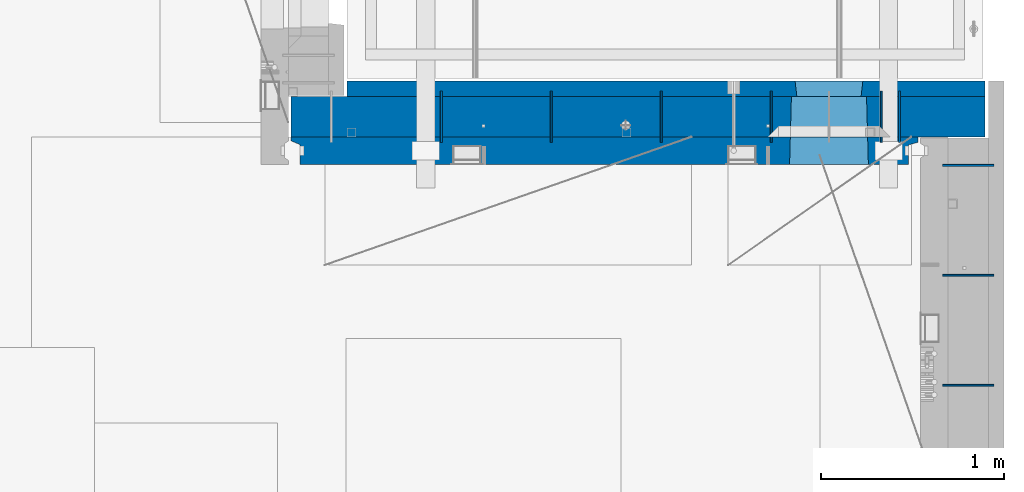
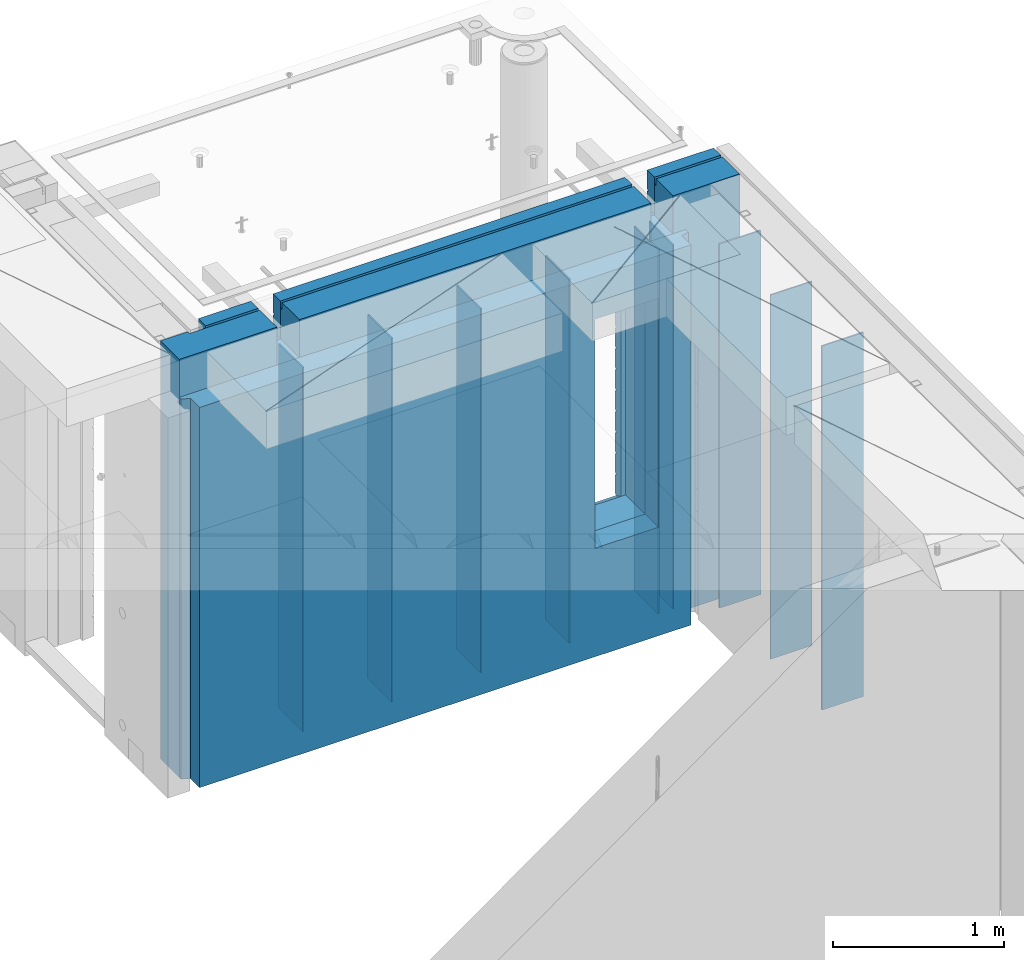
# One storey, part 244 of 352: 12 walls, 2 elements without a shape of their own.
"""IFC2X3 building model written with IfcOpenShell, lengths in millimetres."""

from ifc_helpers import new_model, si_unit, frame, origin_with_axes, place, context, subcontext, project, spatial, faceted_brep, material, type_object, element, aggregate, save


model = new_model("IFC2X3")

# Units and contexts
model_context = context("Model", 3, precision=1e-05, world=origin_with_axes())
body_context = subcontext(model_context, "Body", "Model", "MODEL_VIEW")
ifc_project = project(units=[si_unit("LENGTHUNIT", "METRE", prefix="MILLI"), si_unit("AREAUNIT", "SQUARE_METRE"), si_unit("VOLUMEUNIT", "CUBIC_METRE"), si_unit("MASSUNIT", "GRAM", prefix="KILO"), si_unit("TIMEUNIT", "SECOND"), si_unit("PLANEANGLEUNIT", "RADIAN"), si_unit("SOLIDANGLEUNIT", "STERADIAN"), si_unit("THERMODYNAMICTEMPERATUREUNIT", "DEGREE_CELSIUS"), si_unit("LUMINOUSINTENSITYUNIT", "LUMEN")], contexts=[model_context])

# Site, building, storey
site_placement = place(None, origin_with_axes())
site = spatial("IfcSite", under=ifc_project, at=site_placement, CompositionType="ELEMENT")
building_placement = place(site_placement, origin_with_axes())
building = spatial("IfcBuilding", under=site, at=building_placement, CompositionType="ELEMENT")
storey_placement = place(building_placement, origin_with_axes())
storey = spatial("IfcBuildingStorey", under=building, at=storey_placement, Name="6", CompositionType="ELEMENT", Elevation=0.0)

# Assembly, walls
assembly_1_placement = place(storey_placement, origin_with_axes())
assembly_1 = element("IfcElementAssembly", 1, at=assembly_1_placement, inside=storey, AssemblyPlace="NOTDEFINED", PredefinedType="REINFORCEMENT_UNIT")
ifc_material_1 = material(Name="Undefined")
wall_type_1 = type_object("IfcWallType", PredefinedType="NOTDEFINED")
wall_1_placement = place(assembly_1_placement, frame((32295.0, 20549.9951872276, 98115.0), z_axis=(0.0, 0.0, 1.0), x_axis=(0.0, 1.0, 0.0)))
wall_1 = element("IfcWall", 2, at=wall_1_placement, type_object=wall_type_1, material=ifc_material_1, Name="(PD)", context=body_context, shape_type="Brep", body=[
    faceted_brep([(0.0, 5.0, -1300.0), (0.0, 5.0, 1300.0), (280.0, 5.0, 1300.0), (280.0, 5.0, -1300.0), (0.0, -5.0, 1300.0), (280.0, -5.0, 1300.0), (0.0, -5.0, -1300.0), (280.0, -5.0, -1300.0)], [[[0, 1, 2, 3]], [[1, 4, 5, 2]], [[4, 6, 7, 5]], [[6, 0, 3, 7]], [[5, 7, 3, 2]], [[6, 4, 1, 0]]]),
])
wall_2_placement = place(assembly_1_placement, frame((32895.0, 20549.9951872276, 98115.0), z_axis=(0.0, 0.0, 1.0), x_axis=(0.0, 1.0, 0.0)))
wall_2 = element("IfcWall", 3, at=wall_2_placement, type_object=wall_type_1, material=ifc_material_1, Name="(PD)", context=body_context, shape_type="Brep", body=[
    faceted_brep([(0.0, 5.0, -1300.0), (0.0, 5.0, 1300.0), (280.0, 5.0, 1300.0), (280.0, 5.0, -1300.0), (0.0, -5.0, 1300.0), (280.0, -5.0, 1300.0), (0.0, -5.0, -1300.0), (280.0, -5.0, -1300.0)], [[[0, 1, 2, 3]], [[1, 4, 5, 2]], [[4, 6, 7, 5]], [[6, 0, 3, 7]], [[5, 7, 3, 2]], [[6, 4, 1, 0]]]),
])
wall_3_placement = place(assembly_1_placement, frame((33495.0, 20549.9951872276, 98115.0), z_axis=(0.0, 0.0, 1.0), x_axis=(0.0, 1.0, 0.0)))
wall_3 = element("IfcWall", 4, at=wall_3_placement, type_object=wall_type_1, material=ifc_material_1, Name="(PD)", context=body_context, shape_type="Brep", body=[
    faceted_brep([(0.0, 5.0, -1300.0), (0.0, 5.0, 1300.0), (280.0, 5.0, 1300.0), (280.0, 5.0, -1300.0), (0.0, -5.0, 1300.0), (280.0, -5.0, 1300.0), (0.0, -5.0, -1300.0), (280.0, -5.0, -1300.0)], [[[0, 1, 2, 3]], [[1, 4, 5, 2]], [[4, 6, 7, 5]], [[6, 0, 3, 7]], [[5, 7, 3, 2]], [[6, 4, 1, 0]]]),
])
wall_4_placement = place(assembly_1_placement, frame((34695.0, 20549.9951872276, 98115.0), z_axis=(0.0, 0.0, 1.0), x_axis=(0.0, 1.0, 0.0)))
wall_4 = element("IfcWall", 5, at=wall_4_placement, type_object=wall_type_1, material=ifc_material_1, Name="(PD)", context=body_context, shape_type="Brep", body=[
    faceted_brep([(0.0, 5.0, -1300.0), (0.0, 5.0, 1300.0), (280.0, 5.0, 1300.0), (280.0, 5.0, -1300.0), (0.0, -5.0, 1300.0), (280.0, -5.0, 1300.0), (0.0, -5.0, -1300.0), (280.0, -5.0, -1300.0)], [[[0, 1, 2, 3]], [[1, 4, 5, 2]], [[4, 6, 7, 5]], [[6, 0, 3, 7]], [[5, 7, 3, 2]], [[6, 4, 1, 0]]]),
])
wall_5_placement = place(assembly_1_placement, frame((34795.0, 20549.9951872276, 98115.0), z_axis=(0.0, 0.0, 1.0), x_axis=(0.0, 1.0, 0.0)))
wall_5 = element("IfcWall", 6, at=wall_5_placement, type_object=wall_type_1, material=ifc_material_1, Name="(PD)", context=body_context, shape_type="Brep", body=[
    faceted_brep([(0.0, 5.0, -1300.0), (0.0, 5.0, 1300.0), (280.0, 5.0, 1300.0), (280.0, 5.0, -1300.0), (0.0, -5.0, 1300.0), (280.0, -5.0, 1300.0), (0.0, -5.0, -1300.0), (280.0, -5.0, -1300.0)], [[[0, 1, 2, 3]], [[1, 4, 5, 2]], [[4, 6, 7, 5]], [[6, 0, 3, 7]], [[5, 7, 3, 2]], [[6, 4, 1, 0]]]),
])

assembly_2_placement = place(storey_placement, origin_with_axes())
assembly_2 = element("IfcElementAssembly", 7, at=assembly_2_placement, inside=storey, AssemblyPlace="NOTDEFINED", PredefinedType="REINFORCEMENT_UNIT")
wall_6_placement = place(assembly_2_placement, frame((35030.0, 19225.0002441406, 98115.0), z_axis=(0.0, 0.0, 1.0), x_axis=(1.0, 0.0, 0.0)))
wall_6 = element("IfcWall", 8, at=wall_6_placement, type_object=wall_type_1, material=ifc_material_1, Name="(PD)", context=body_context, shape_type="Brep", body=[
    faceted_brep([(0.0, 5.0, -1300.0), (0.0, 5.0, 1300.0), (280.0, 5.0, 1300.0), (280.0, 5.0, -1300.0), (0.0, -5.0, 1300.0), (280.0, -5.0, 1300.0), (0.0, -5.0, -1300.0), (280.0, -5.0, -1300.0)], [[[0, 1, 2, 3]], [[1, 4, 5, 2]], [[4, 6, 7, 5]], [[6, 0, 3, 7]], [[5, 7, 3, 2]], [[6, 4, 1, 0]]]),
])
wall_7_placement = place(assembly_2_placement, frame((35030.0, 19825.0002441406, 98115.0), z_axis=(0.0, 0.0, 1.0), x_axis=(1.0, 0.0, 0.0)))
wall_7 = element("IfcWall", 9, at=wall_7_placement, type_object=wall_type_1, material=ifc_material_1, Name="(PD)", context=body_context, shape_type="Brep", body=[
    faceted_brep([(0.0, 5.0, -1300.0), (0.0, 5.0, 1300.0), (280.0, 5.0, 1300.0), (280.0, 5.0, -1300.0), (0.0, -5.0, 1300.0), (280.0, -5.0, 1300.0), (0.0, -5.0, -1300.0), (280.0, -5.0, -1300.0)], [[[0, 1, 2, 3]], [[1, 4, 5, 2]], [[4, 6, 7, 5]], [[6, 0, 3, 7]], [[5, 7, 3, 2]], [[6, 4, 1, 0]]]),
])

# Wall
wall_8_placement = place(assembly_1_placement, frame((34095.0, 20549.9951872276, 98115.0), z_axis=(0.0, 0.0, 1.0), x_axis=(0.0, 1.0, 0.0)))
wall_8 = element("IfcWall", 10, at=wall_8_placement, type_object=wall_type_1, material=ifc_material_1, Name="(PD)", context=body_context, shape_type="Brep", body=[
    faceted_brep([(0.0, 5.0, -1300.0), (0.0, 5.0, 1300.0), (280.0, 5.0, 1300.0), (280.0, 5.0, -1300.0), (0.0, -5.0, 1300.0), (280.0, -5.0, 1300.0), (0.0, -5.0, -1300.0), (280.0, -5.0, -1300.0)], [[[0, 1, 2, 3]], [[1, 4, 5, 2]], [[4, 6, 7, 5]], [[6, 0, 3, 7]], [[5, 7, 3, 2]], [[6, 4, 1, 0]]]),
])

wall_9_placement = place(assembly_2_placement, frame((35030.0, 20425.0002441406, 98115.0), z_axis=(0.0, 0.0, 1.0), x_axis=(1.0, 0.0, 0.0)))
wall_9 = element("IfcWall", 11, at=wall_9_placement, type_object=wall_type_1, material=ifc_material_1, Name="(PD)", context=body_context, shape_type="Brep", body=[
    faceted_brep([(0.0, 5.0, -1300.0), (0.0, 5.0, 1300.0), (280.0, 5.0, 1300.0), (280.0, 5.0, -1300.0), (0.0, -5.0, 1300.0), (280.0, -5.0, 1300.0), (0.0, -5.0, -1300.0), (280.0, -5.0, -1300.0)], [[[0, 1, 2, 3]], [[1, 4, 5, 2]], [[4, 6, 7, 5]], [[6, 0, 3, 7]], [[5, 7, 3, 2]], [[6, 4, 1, 0]]]),
])

aggregate(assembly_2, [wall_6, wall_7, wall_9])

ifc_material_2 = material(Name="COS5gt")
wall_type_2 = type_object("IfcWallType", PredefinedType="NOTDEFINED")
wall_10_placement = place(assembly_1_placement, frame((31475.0, 20689.9951872276, 98247.5), z_axis=(0.0, 0.0, 1.0), x_axis=(1.0, 0.0, 0.0)))
wall_10 = element("IfcWall", 12, at=wall_10_placement, type_object=wall_type_2, material=ifc_material_2, context=body_context, shape_type="Brep", body=[
    faceted_brep([(810.0, 110.0, 1442.5), (810.0, 90.0, 1442.5), (3185.0, 90.0, 1442.5), (3185.0, 110.0, 1442.5), (810.0, 90.0, 1492.5), (810.0, -110.0, 1492.5), (3185.0, -110.0, 1492.5), (3185.0, 90.0, 1492.5), (184.0, 90.0, 1442.5), (184.0, 90.0, 1492.5), (660.0, 90.0, 1492.5), (660.0, 90.0, 1442.5), (184.0, 110.0, 1492.5), (184.0, 110.0, 1442.5), (0.0, 110.0, 1492.5), (0.0, -110.0, 1492.5), (660.0, -110.0, 1492.5), (0.0, -110.0, -1492.5), (0.0, 110.0, -1492.5), (3785.0, 90.0, -1492.5), (184.0, 90.0, -1492.5), (184.0, 90.0, -1442.5), (3785.0, 90.0, -1442.5), (3785.0, -110.0, -1492.5), (184.0, 110.0, -1492.5), (184.0, 110.0, -1442.5), (3785.0, 110.0, -1442.5), (3785.0, 110.0, 1442.5), (3785.0, 90.0, 1442.5), (3785.0, 90.0, 1492.5), (3785.0, -110.0, 1492.5), (3335.0, 90.0, 1492.5), (3335.0, -110.0, 1492.5), (3185.0, -110.000000000004, 1222.5), (810.0, -110.0, 1222.5), (660.0, -110.0, 1222.5), (3335.0, -110.000000000004, 1222.5), (2724.05956312561, -110.000000000004, -713.445945945947), (2724.05956312561, -110.000000000007, 913.445945945947), (3145.94145501751, -110.000000000007, 913.445945945947), (3145.94145501751, -110.000000000004, -713.445945945947), (2730.00550907156, 110.0, -702.5), (2730.00550907156, 110.0, 907.5), (2730.00550907156, 110.0, -707.5), (3139.99550907157, 110.0, -707.5), (3109.99550907157, 110.0, -707.5), (2760.00550907156, 110.0, -707.5), (3139.99550907157, 110.0, 907.5), (3139.99550907157, 110.0, -702.5), (660.0, 110.0, 1442.5), (660.0, 109.999999999996, 1222.5), (810.0, 109.999999999996, 1222.5), (3185.0, 109.999999999996, 1222.5), (3335.0, 109.999999999996, 1222.5), (3335.0, 110.0, 1442.5), (3335.0, 90.0, 1442.5)], [[[0, 1, 2, 3]], [[4, 5, 6, 7]], [[8, 9, 10, 11]], [[12, 9, 8, 13]], [[9, 12, 14, 15, 16, 10]], [[17, 15, 14, 18]], [[19, 20, 21, 22]], [[23, 17, 18, 24, 20, 19]], [[25, 21, 20, 24]], [[26, 22, 21, 25]], [[27, 28, 29, 30, 23, 19, 22, 26]], [[30, 29, 31, 32]], [[33, 6, 5, 34, 35, 16, 15, 17, 23, 30, 32, 36], [37, 38, 39, 40]], [[41, 42, 38, 37, 43]], [[40, 44, 45, 46, 43, 37]], [[39, 47, 48, 44, 40]], [[38, 42, 47, 39]], [[27, 26, 25, 24, 18, 14, 12, 13, 49, 50, 51, 0, 3, 52, 53, 54], [41, 43, 46, 45, 44, 48, 47, 42]], [[28, 27, 54, 55]], [[29, 28, 55, 31]], [[54, 53, 36, 32, 31, 55]], [[52, 33, 36, 53]], [[3, 2, 7, 6, 33, 52]], [[1, 4, 7, 2]], [[0, 51, 34, 5, 4, 1]], [[50, 35, 34, 51]], [[49, 11, 10, 16, 35, 50]], [[13, 8, 11, 49]]]),
])

ifc_material_3 = material(Name="CONCRETE/C30/37")
wall_type_3 = type_object("IfcWallType", PredefinedType="NOTDEFINED")
wall_11_placement = place(assembly_1_placement, frame((31780.0, 20842.4951872276, 98247.5), z_axis=(0.0, 0.0, 1.0), x_axis=(1.0, 0.0, 0.0)))
wall_11 = element("IfcWall", 13, at=wall_11_placement, type_object=wall_type_3, material=ifc_material_3, context=body_context, shape_type="Brep", body=[
    faceted_brep([(3480.0, -42.5, 1492.5), (3480.0, 42.5, 1492.5), (3030.0, 42.5, 1492.5), (3030.0, -42.5, 1492.5), (3480.0, 42.4999992431694, 1356.99999988925), (3030.0, 42.4999993410347, 1356.99999988925), (3480.0, 32.4999991127006, 1355.00000040044), (3480.0, 32.4999992507037, 1344.99999999926), (3030.0, 32.4999992507037, 1344.99999999926), (3030.0, 32.4999991127006, 1355.00000040044), (3480.0, 42.4999996036895, 1342.99999994476), (3030.0, 42.4999996549377, 1342.99999994476), (3480.0, 42.4999993831152, 892.999999944761), (0.0, 42.5, 892.999999944761), (0.0, 32.4999992507037, 894.999999999258), (3480.0, 32.4999992507037, 894.999999999258), (0.0, 32.4999991127006, 905.00000040044), (3480.0, 32.4999991127006, 905.00000040044), (3480.0, 42.4999992431694, 906.999999889245), (0.0, 42.5, 906.999999889245), (0.0, 42.5, 1042.99999994476), (3480.0, 42.4999994189675, 1042.99999994476), (0.0, 32.4999992507037, 1044.99999999926), (3480.0, 32.4999992507037, 1044.99999999926), (0.0, 32.4999991127006, 1055.00000040044), (3480.0, 32.4999991127006, 1055.00000040044), (3480.0, 42.4999992431694, 1056.99999988925), (0.0, 42.5, 1056.99999988925), (0.0, 42.5, 1192.99999994476), (3480.0, 42.4999994795144, 1192.99999994476), (0.0, 32.4999992507037, 1194.99999999926), (3480.0, 32.4999992507037, 1194.99999999926), (0.0, 32.4999991127006, 1205.00000040044), (3480.0, 32.4999991127006, 1205.00000040044), (3480.0, 42.4999992431694, 1206.99999988925), (0.0, 42.5, 1206.99999988925), (-3.63797880709171e-12, 32.4999992507037, 1344.99999999926), (-3.63797880709171e-12, 32.4999991127006, 1355.00000040044), (355.0, 32.4999991127006, 1355.00000040044), (355.0, 32.4999992507037, 1344.99999999926), (0.0, 42.5, 1342.99999994476), (355.0, 42.4999999595711, 1342.99999994476), (505.0, 32.4999992507037, 1344.99999999926), (505.0, 32.4999991127006, 1355.00000040044), (2880.0, 32.4999991127006, 1355.00000040044), (2880.0, 32.4999992507037, 1344.99999999926), (505.0, 42.4999999424908, 1342.99999994476), (2880.0, 42.4999996720217, 1342.99999994476), (355.0, 42.4999998715975, 1222.5), (505.0, 42.4999998467429, 1222.5), (2880.0, 42.4999994331811, 1222.5), (3030.0, 42.4999994081736, 1222.5), (355.0, -42.5, 1222.5), (505.0, -42.5, 1222.5), (505.0, 42.5, 1492.5), (505.0, 42.4999998901731, 1356.99999988925), (505.0, -42.5, 1492.5), (2880.0, -42.5, 1492.5), (2880.0, 42.5, 1492.5), (2880.0, 42.4999993736565, 1356.99999988925), (2880.0, -42.5000000000036, 1222.5), (3030.0, -42.5000000000036, 1222.5), (3480.0, -42.5, -1492.5), (3480.0, 42.5, -1492.5), (3480.0, 42.5, -1357.00000005524), (3480.0, 32.4999992507037, -1355.00000000074), (3480.0, 32.4999991127006, -1344.99999959956), (3480.0, 42.4999992431694, -1343.00000011075), (3480.0, 42.4999992794692, -1207.00000005524), (3480.0, 32.4999992507037, -1205.00000000074), (3480.0, 32.4999991127006, -1194.99999959956), (3480.0, 42.4999992431694, -1193.00000011075), (3480.0, 42.4999992814955, -1057.00000005524), (3480.0, 32.4999992507037, -1055.00000000074), (3480.0, 32.4999991127006, -1044.99999959956), (3480.0, 42.4999992431694, -1043.00000011075), (3480.0, 42.4999992837656, -907.000000055239), (3480.0, 32.4999992507037, -905.000000000742), (3480.0, 32.4999991127006, -894.99999959956), (3480.0, 42.4999992431694, -893.000000110755), (3480.0, 42.4999992863159, -757.000000055239), (3480.0, 32.4999992507037, -755.000000000742), (3480.0, 32.4999991127006, -744.99999959956), (3480.0, 42.4999992431694, -743.000000110755), (3480.0, 42.4999992892117, -607.000000055239), (3480.0, 32.4999992507037, -605.000000000742), (3480.0, 32.4999991127006, -594.99999959956), (3480.0, 42.4999992431694, -593.000000110755), (3480.0, 42.4999992925223, -457.000000055239), (3480.0, 32.4999992507037, -455.000000000742), (3480.0, 32.4999991127006, -444.99999959956), (3480.0, 42.4999992431694, -443.000000110755), (3480.0, 42.4999992963494, -307.000000055239), (3480.0, 32.4999992507037, -305.000000000742), (3480.0, 32.4999991127006, -294.99999959956), (3480.0, 42.4999992431694, -293.000000110755), (3480.0, 42.4999993008169, -157.000000055239), (3480.0, 32.4999992507037, -155.000000000742), (3480.0, 32.4999991127006, -144.99999959956), (3480.0, 42.4999992431694, -143.000000110755), (3480.0, 42.4999993061028, -7.00000005523907), (3480.0, 32.4999992507037, -5.00000000074215), (3480.0, 32.4999991127006, 5.0000004004396), (3480.0, 42.4999992431694, 6.99999988924537), (3480.0, 42.4999993124584, 142.999999944761), (3480.0, 32.4999992507037, 144.999999999258), (3480.0, 32.4999991127006, 155.00000040044), (3480.0, 42.4999992431694, 156.999999889245), (3480.0, 42.49999932024, 292.999999944761), (3480.0, 32.4999992507037, 294.999999999258), (3480.0, 32.4999991127006, 305.00000040044), (3480.0, 42.4999992431694, 306.999999889245), (3480.0, 42.4999993299934, 442.999999944761), (3480.0, 32.4999992507037, 444.999999999258), (3480.0, 32.4999991127006, 455.00000040044), (3480.0, 42.4999992431694, 456.999999889245), (3480.0, 42.4999993425699, 592.999999944761), (3480.0, 32.4999992507037, 594.999999999258), (3480.0, 32.4999991127006, 605.00000040044), (3480.0, 42.4999992431694, 606.999999889245), (3480.0, 42.4999993594065, 742.999999944761), (3480.0, 32.4999992507037, 744.999999999258), (3480.0, 32.4999991127006, 755.00000040044), (3480.0, 42.4999992431694, 756.999999889245), (0.0, -42.5, -1492.5), (0.0, 42.5, -1492.5), (0.0, 42.5, -1357.00000005524), (0.0, 32.4999992507037, -1355.00000000074), (0.0, 32.4999991127006, -1344.99999959956), (0.0, 42.5, -1343.00000011075), (0.0, 42.5, -1207.00000005524), (0.0, 32.4999992507037, -1205.00000000074), (0.0, 32.4999991127006, -1194.99999959956), (0.0, 42.5, -1193.00000011075), (0.0, 42.5, -1057.00000005524), (0.0, 32.4999992507037, -1055.00000000074), (0.0, 32.4999991127006, -1044.99999959956), (0.0, 42.5, -1043.00000011075), (0.0, 42.5, -907.000000055239), (0.0, 32.4999992507037, -905.000000000742), (0.0, 32.4999991127006, -894.99999959956), (0.0, 42.5, -893.000000110755), (0.0, 42.5, -757.000000055239), (2445.00550907156, 42.4999994985737, -757.000000055239), (2445.00550907156, 42.5, -757.5), (2814.99550907157, 42.5, -757.5), (2814.99550907157, 42.5, -757.000000055239), (2445.1570241794, 41.2121215834159, -756.742424460826), (2814.84399396603, 41.2121216029336, -756.742424472308), (0.0, 32.4999992507037, -755.000000000742), (0.0, 32.4999991127006, 755.00000040044), (0.0, 42.5, 756.999999889245), (2445.00550907156, 42.4999994682585, 756.999999889245), (2446.18197976419, 32.4999991127006, 755.00000040044), (0.0, 32.4999992507037, 744.999999999258), (2446.18197974795, 32.4999992507037, 744.999999999258), (0.0, 42.5, 742.999999944761), (2445.00550907156, 42.4999995499275, 742.999999944761), (0.0, 42.5, 606.999999889245), (2445.00550907156, 42.4999994682585, 606.999999889245), (3.63797880709171e-12, 32.4999991127006, 605.00000040044), (2446.18197976419, 32.4999991127006, 605.00000040044), (3.63797880709171e-12, 32.4999992507037, 594.999999999258), (2446.18197974795, 32.4999992507037, 594.999999999258), (0.0, 42.5, 592.999999944761), (2445.00550907156, 42.4999995380967, 592.999999944761), (0.0, 42.5, 456.999999889245), (2445.00550907156, 42.4999994682585, 456.999999889245), (0.0, 32.4999991127006, 455.00000040044), (2446.18197976419, 32.4999991127006, 455.00000040044), (0.0, 32.4999992507037, 444.999999999258), (2446.18197974795, 32.4999992507037, 444.999999999258), (0.0, 42.5, 442.999999944761), (2445.00550907156, 42.4999995292637, 442.999999944761), (0.0, 42.5, 306.999999889245), (2445.00550907156, 42.4999994682585, 306.999999889245), (-3.63797880709171e-12, 32.4999991127006, 305.00000040044), (2446.18197976419, 32.4999991127006, 305.00000040044), (-3.63797880709171e-12, 32.4999992507037, 294.999999999258), (2446.18197974795, 32.4999992507037, 294.999999999258), (0.0, 42.5, 292.999999944761), (2445.00550907156, 42.4999995224098, 292.999999944761), (0.0, 42.5, 156.999999889245), (2445.00550907156, 42.4999994682585, 156.999999889245), (-3.63797880709171e-12, 32.4999991127006, 155.00000040044), (2446.18197976419, 32.4999991127006, 155.00000040044), (-3.63797880709171e-12, 32.4999992507037, 144.999999999258), (2446.18197974795, 32.4999992507037, 144.999999999258), (0.0, 42.5, 142.999999944761), (2445.00550907156, 42.4999995169419, 142.999999944761), (0.0, 42.5, 6.99999988924537), (2445.00550907156, 42.4999994682585, 6.99999988924537), (0.0, 32.4999991127006, 5.0000004004396), (2446.18197976419, 32.4999991127006, 5.0000004004396), (0.0, 32.4999992507037, -5.00000000074215), (2446.18197974795, 32.4999992507037, -5.00000000074215), (0.0, 42.5, -7.00000005523907), (2445.00550907156, 42.4999995124781, -7.00000005523907), (0.0, 42.5, -143.000000110755), (2445.00550907156, 42.4999994682585, -143.000000110755), (3.63797880709171e-12, 32.4999991127006, -144.99999959956), (2446.18197976419, 32.4999991127006, -144.99999959956), (3.63797880709171e-12, 32.4999992507037, -155.000000000742), (2446.18197974795, 32.4999992507037, -155.000000000742), (0.0, 42.5, -157.000000055239), (2445.00550907156, 42.4999995087601, -157.000000055239), (0.0, 42.5, -293.000000110755), (2445.00550907156, 42.4999994682585, -293.000000110755), (0.0, 32.4999991127006, -294.99999959956), (2446.18197976419, 32.4999991127006, -294.99999959956), (0.0, 32.4999992507037, -305.000000000742), (2446.18197974795, 32.4999992507037, -305.000000000742), (0.0, 42.5, -307.000000055239), (2445.00550907156, 42.4999995056241, -307.000000055239), (0.0, 42.5, -443.000000110755), (2445.00550907156, 42.4999994682585, -443.000000110755), (0.0, 32.4999991127006, -444.99999959956), (2446.18197976419, 32.4999991127006, -444.99999959956), (0.0, 32.4999992507037, -455.000000000742), (2446.18197974795, 32.4999992507037, -455.000000000742), (0.0, 42.5, -457.000000055239), (2445.00550907156, 42.4999995029357, -457.000000055239), (0.0, 42.5, -593.000000110755), (2445.00550907156, 42.4999994682585, -593.000000110755), (3.63797880709171e-12, 32.4999991127006, -594.99999959956), (2446.18197976419, 32.4999991127006, -594.99999959956), (3.63797880709171e-12, 32.4999992507037, -605.000000000742), (2446.18197974795, 32.4999992507037, -605.000000000742), (0.0, 42.5, -607.000000055239), (2445.00550907156, 42.499999500611, -607.000000055239), (0.0, 42.5, -743.000000110755), (2445.00550907156, 42.4999994682585, -743.000000110755), (0.0, 32.4999991127006, -744.99999959956), (2446.18197976419, 32.4999991127006, -744.99999959956), (2446.18197975344, 32.4999992040284, -751.617646590603), (2455.00550907156, -42.5, -707.5), (2804.99550907157, -42.5, -707.5), (2813.81903838969, 32.4999992040284, -751.617646590603), (2813.81903837895, 32.4999991127006, -744.99999959956), (2814.99550907157, 42.4999993877937, -743.000000110755), (2814.99550907157, 42.4999994250393, -607.000000055239), (2813.81903839519, 32.4999992507037, -605.000000000742), (2813.81903837895, 32.4999991127006, -594.99999959956), (2814.99550907157, 42.4999993877937, -593.000000110755), (2814.99550907157, 42.4999994277168, -457.000000055239), (2813.81903839519, 32.4999992507037, -455.000000000742), (2813.81903837895, 32.4999991127006, -444.99999959956), (2814.99550907157, 42.4999993877937, -443.000000110755), (2814.99550907157, 42.4999994308128, -307.000000055239), (2813.81903839519, 32.4999992507037, -305.000000000742), (2813.81903837895, 32.4999991127006, -294.99999959956), (2814.99550907157, 42.4999993877937, -293.000000110755), (2814.99550907157, 42.4999994344253, -157.000000055239), (2813.81903839519, 32.4999992507037, -155.000000000742), (2813.81903837895, 32.4999991127006, -144.99999959956), (2814.99550907157, 42.4999993877937, -143.000000110755), (2814.99550907157, 42.4999994387035, -7.00000005523907), (2813.81903839519, 32.4999992507037, -5.00000000074215), (2813.81903837895, 32.4999991127006, 5.0000004004396), (2814.99550907157, 42.4999993877937, 6.99999988924537), (2814.99550907157, 42.499999443844, 142.999999944761), (2813.81903839519, 32.4999992507037, 144.999999999258), (2813.81903837895, 32.4999991127006, 155.00000040044), (2814.99550907157, 42.4999993877937, 156.999999889245), (2814.99550907157, 42.4999994501377, 292.999999944761), (2813.81903839519, 32.4999992507037, 294.999999999258), (2813.81903837895, 32.4999991127006, 305.00000040044), (2814.99550907157, 42.4999993877937, 306.999999889245), (2814.99550907157, 42.4999994580285, 442.999999944761), (2813.81903839519, 32.4999992507037, 444.999999999258), (2813.81903837895, 32.4999991127006, 455.00000040044), (2814.99550907157, 42.4999993877937, 456.999999889245), (2814.99550907157, 42.4999994682003, 592.999999944761), (2813.81903839519, 32.4999992507037, 594.999999999258), (2813.81903837895, 32.4999991127006, 605.00000040044), (2814.99550907157, 42.4999993877937, 606.999999889245), (2814.99550907157, 42.4999994818209, 742.999999944761), (2813.81903839519, 32.4999992507037, 744.999999999258), (2813.81903837895, 32.4999991127006, 755.00000040044), (2814.99550907157, 42.4999993877937, 756.999999889245), (2455.00550907156, 42.5, 882.5), (2445.00550907156, 42.5, 882.5), (2814.99550907157, 42.5, 882.5), (2804.99550907157, 42.5, 882.5), (2455.00550907156, -42.5, 882.5), (2455.00550907156, -42.5, 887.5), (2804.99550907157, -42.5, 887.5), (2804.99550907157, -42.5, 882.5), (355.0, -42.5, 1492.5), (0.0, -42.5, 1492.5), (0.0, 42.5, 1492.5), (355.0, 42.5, 1492.5), (0.0, 42.5, 1356.99999988925), (355.0, 42.4999999227948, 1356.99999988925)], [[[0, 1, 2, 3]], [[1, 4, 5, 2]], [[6, 7, 8, 9]], [[7, 10, 11, 8]], [[12, 13, 14, 15]], [[15, 14, 16, 17]], [[18, 17, 16, 19]], [[18, 19, 20, 21]], [[21, 20, 22, 23]], [[23, 22, 24, 25]], [[26, 25, 24, 27]], [[26, 27, 28, 29]], [[29, 28, 30, 31]], [[31, 30, 32, 33]], [[34, 33, 32, 35]], [[36, 37, 38, 39]], [[40, 36, 39, 41]], [[42, 43, 44, 45]], [[46, 42, 45, 47]], [[10, 34, 35, 40, 41, 48, 49, 46, 47, 50, 51, 11]], [[48, 52, 53, 49]], [[54, 55, 43, 42, 46, 49, 53, 56]], [[54, 56, 57, 58]], [[55, 54, 58, 59]], [[43, 55, 59, 44]], [[58, 57, 60, 50, 47, 45, 44, 59]], [[50, 60, 61, 51]], [[2, 5, 9, 8, 11, 51, 61, 3]], [[4, 6, 9, 5]], [[1, 0, 62, 63, 64, 65, 66, 67, 68, 69, 70, 71, 72, 73, 74, 75, 76, 77, 78, 79, 80, 81, 82, 83, 84, 85, 86, 87, 88, 89, 90, 91, 92, 93, 94, 95, 96, 97, 98, 99, 100, 101, 102, 103, 104, 105, 106, 107, 108, 109, 110, 111, 112, 113, 114, 115, 116, 117, 118, 119, 120, 121, 122, 123, 12, 15, 17, 18, 21, 23, 25, 26, 29, 31, 33, 34, 10, 7, 6, 4]], [[124, 125, 63, 62]], [[63, 125, 126, 64]], [[64, 126, 127, 65]], [[65, 127, 128, 66]], [[67, 66, 128, 129]], [[67, 129, 130, 68]], [[68, 130, 131, 69]], [[69, 131, 132, 70]], [[71, 70, 132, 133]], [[71, 133, 134, 72]], [[72, 134, 135, 73]], [[73, 135, 136, 74]], [[75, 74, 136, 137]], [[75, 137, 138, 76]], [[76, 138, 139, 77]], [[77, 139, 140, 78]], [[79, 78, 140, 141]], [[80, 79, 141, 142, 143, 144, 145, 146]], [[143, 147, 144]], [[144, 147, 148, 145]], [[146, 145, 148]], [[147, 143, 142, 149, 81, 80, 146, 148]], [[150, 151, 152, 153]], [[154, 150, 153, 155]], [[156, 154, 155, 157]], [[158, 156, 157, 159]], [[160, 158, 159, 161]], [[162, 160, 161, 163]], [[164, 162, 163, 165]], [[166, 164, 165, 167]], [[168, 166, 167, 169]], [[170, 168, 169, 171]], [[172, 170, 171, 173]], [[174, 172, 173, 175]], [[176, 174, 175, 177]], [[178, 176, 177, 179]], [[180, 178, 179, 181]], [[182, 180, 181, 183]], [[184, 182, 183, 185]], [[186, 184, 185, 187]], [[188, 186, 187, 189]], [[190, 188, 189, 191]], [[192, 190, 191, 193]], [[194, 192, 193, 195]], [[196, 194, 195, 197]], [[198, 196, 197, 199]], [[200, 198, 199, 201]], [[202, 200, 201, 203]], [[204, 202, 203, 205]], [[206, 204, 205, 207]], [[208, 206, 207, 209]], [[210, 208, 209, 211]], [[212, 210, 211, 213]], [[214, 212, 213, 215]], [[216, 214, 215, 217]], [[218, 216, 217, 219]], [[220, 218, 219, 221]], [[222, 220, 221, 223]], [[224, 222, 223, 225]], [[226, 224, 225, 227]], [[228, 226, 227, 229]], [[230, 228, 229, 231]], [[232, 230, 231, 233]], [[234, 235, 236, 237]], [[82, 81, 149, 232, 233, 234, 237, 238]], [[83, 82, 238, 239]], [[84, 83, 239, 240]], [[85, 84, 240, 241]], [[86, 85, 241, 242]], [[87, 86, 242, 243]], [[88, 87, 243, 244]], [[89, 88, 244, 245]], [[90, 89, 245, 246]], [[91, 90, 246, 247]], [[92, 91, 247, 248]], [[93, 92, 248, 249]], [[94, 93, 249, 250]], [[95, 94, 250, 251]], [[96, 95, 251, 252]], [[97, 96, 252, 253]], [[98, 97, 253, 254]], [[99, 98, 254, 255]], [[100, 99, 255, 256]], [[101, 100, 256, 257]], [[102, 101, 257, 258]], [[103, 102, 258, 259]], [[104, 103, 259, 260]], [[105, 104, 260, 261]], [[106, 105, 261, 262]], [[107, 106, 262, 263]], [[108, 107, 263, 264]], [[109, 108, 264, 265]], [[110, 109, 265, 266]], [[111, 110, 266, 267]], [[112, 111, 267, 268]], [[113, 112, 268, 269]], [[114, 113, 269, 270]], [[115, 114, 270, 271]], [[116, 115, 271, 272]], [[117, 116, 272, 273]], [[118, 117, 273, 274]], [[119, 118, 274, 275]], [[120, 119, 275, 276]], [[121, 120, 276, 277]], [[122, 121, 277, 278]], [[123, 122, 278, 279]], [[280, 281, 152, 151, 13, 12, 123, 279, 282, 283]], [[284, 235, 234, 233, 231, 229, 227, 225, 223, 221, 219, 217, 215, 213, 211, 209, 207, 205, 203, 201, 199, 197, 195, 193, 191, 189, 187, 185, 183, 181, 179, 177, 175, 173, 171, 169, 167, 165, 163, 161, 159, 157, 155, 153, 152, 281, 285]], [[280, 283, 282, 286, 285, 281]], [[279, 278, 277, 276, 275, 274, 273, 272, 271, 270, 269, 268, 267, 266, 265, 264, 263, 262, 261, 260, 259, 258, 257, 256, 255, 254, 253, 252, 251, 250, 249, 248, 247, 246, 245, 244, 243, 242, 241, 240, 239, 238, 237, 236, 287, 286, 282]], [[60, 57, 56, 53, 52, 288, 289, 124, 62, 0, 3, 61], [236, 235, 284, 285, 286, 287]], [[290, 289, 288, 291]], [[36, 40, 35, 32, 30, 28, 27, 24, 22, 20, 19, 16, 14, 13, 151, 150, 154, 156, 158, 160, 162, 164, 166, 168, 170, 172, 174, 176, 178, 180, 182, 184, 186, 188, 190, 192, 194, 196, 198, 200, 202, 204, 206, 208, 210, 212, 214, 216, 218, 220, 222, 224, 226, 228, 230, 232, 149, 142, 141, 140, 139, 138, 137, 136, 135, 134, 133, 132, 131, 130, 129, 128, 127, 126, 125, 124, 289, 290, 292, 37]], [[37, 292, 293, 38]], [[291, 288, 52, 48, 41, 39, 38, 293]], [[292, 290, 291, 293]]]),
])

ifc_material_4 = material(Name="CONCRETE/C25/30")
wall_type_4 = type_object("IfcWallType", PredefinedType="NOTDEFINED")
wall_12_placement = place(assembly_1_placement, frame((31475.0, 20504.9951872276, 98112.5), z_axis=(0.0, 0.0, 1.0), x_axis=(1.0, 0.0, 0.0)))
wall_12 = element("IfcWall", 14, at=wall_12_placement, type_object=wall_type_4, material=ifc_material_4, context=body_context, shape_type="Brep", body=[
    faceted_brep([(3370.0, -75.0, 1357.5), (3370.0, -75.0, -1357.5), (3370.0, 32.0, -1357.5), (3370.0, 32.0, 1357.5), (3420.0, 75.0, 1357.5), (0.0, 75.0, 1357.5), (0.0, 53.6645811319431, 1357.5), (49.9951872275633, 32.0, 1357.5), (49.9951872275633, -75.0, 1357.5), (3420.0, 45.0, 1357.5), (49.9951872275633, 32.0, -1357.5), (49.9951872275633, -75.0, -1357.5), (0.0, 53.6645811319431, -1357.5), (0.0, 75.0, -1357.5), (3420.0, 75.0, -1357.5), (3420.0, 45.0, -1357.5), (2720.00550907156, -75.0, 1052.5), (2724.05956312561, 75.0, 1048.44594594595), (3145.94145501751, 75.0, 1048.44594594595), (3149.99550907157, -75.0, 1052.5), (2724.05956312561, 75.0, -578.445945945947), (3145.94145501751, 75.0, -578.445945945947), (3149.99550907157, -75.0, -582.5), (2720.00550907156, -75.0, -582.5)], [[[0, 1, 2, 3]], [[4, 5, 6, 7, 8, 0, 3, 9]], [[7, 10, 11, 8]], [[6, 12, 10, 7]], [[5, 13, 12, 6]], [[1, 11, 10, 12, 13, 14, 15, 2]], [[9, 3, 2, 15]], [[14, 4, 9, 15]], [[16, 17, 18, 19]], [[13, 5, 4, 14], [20, 21, 18, 17]], [[19, 18, 21, 22]], [[8, 11, 1, 0], [23, 16, 19, 22]], [[17, 16, 23, 20]], [[22, 21, 20, 23]]]),
])

aggregate(assembly_1, [wall_1, wall_2, wall_3, wall_4, wall_5, wall_8, wall_11, wall_10, wall_12])

save(model, "model.ifc")
